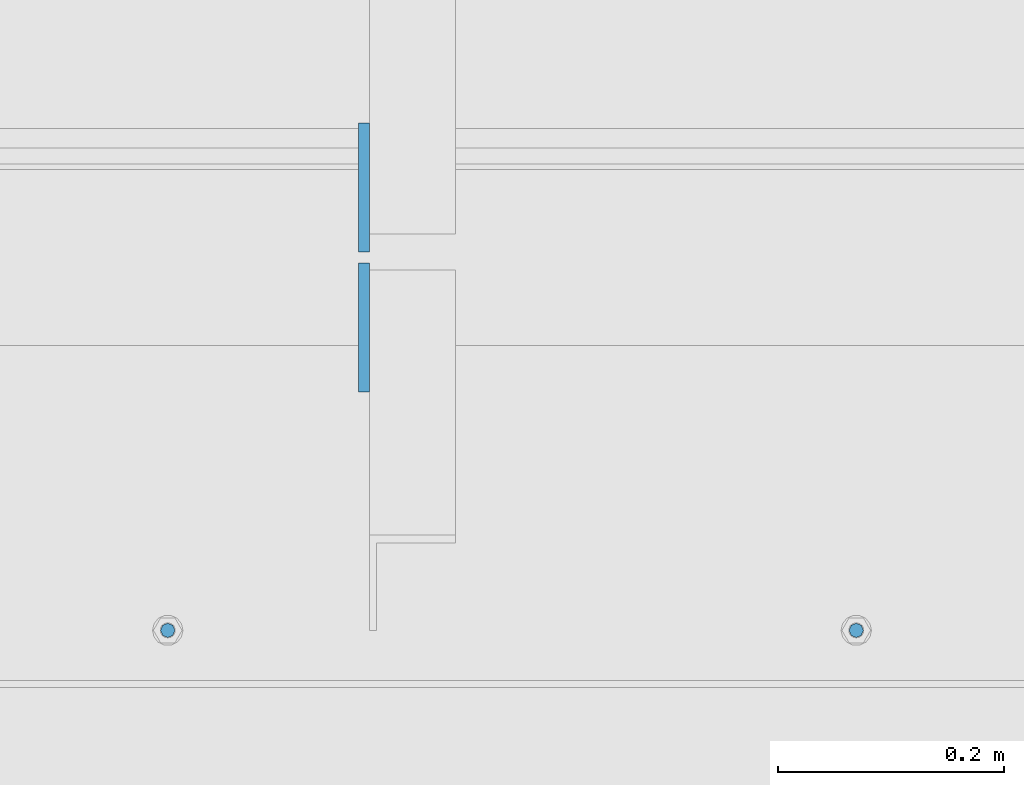
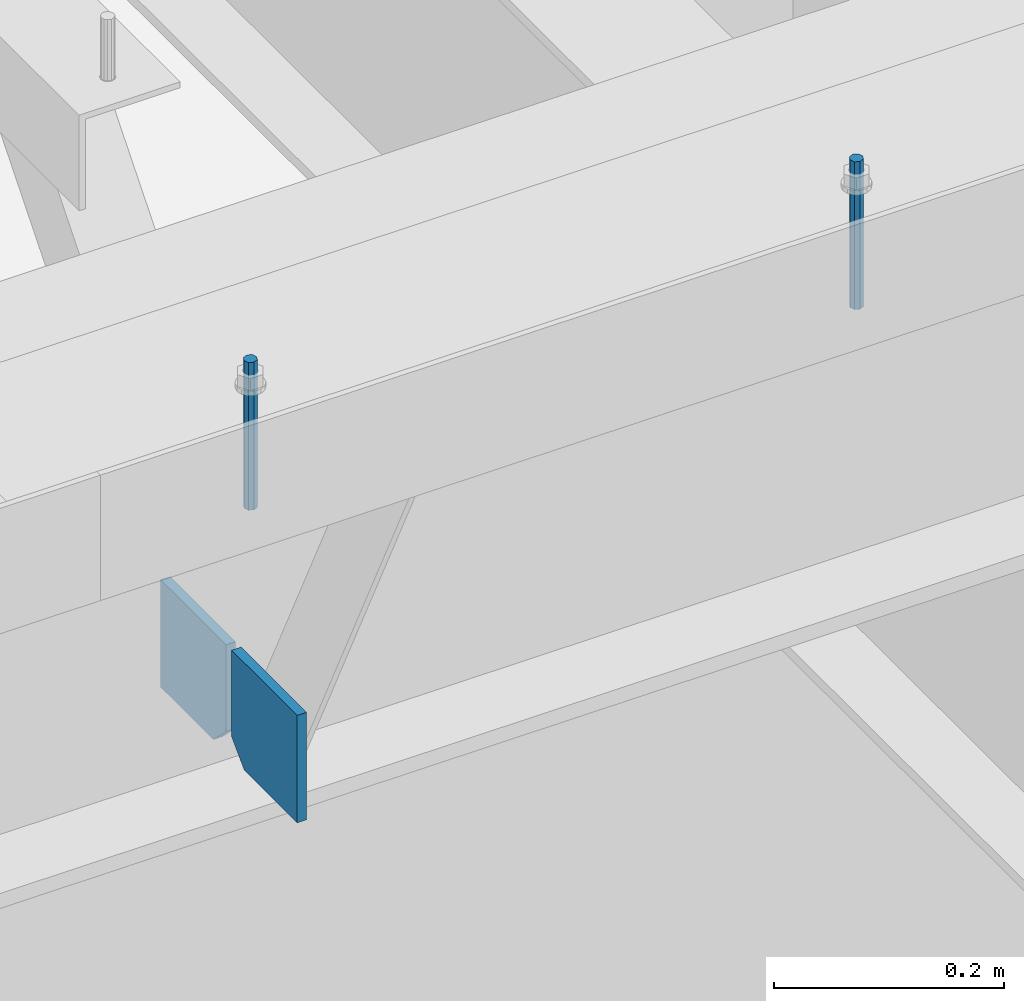
# One storey, part 432 of 1179: 4 columns, 1 element without a shape of its own.
"""IFC2X3 building model written with IfcOpenShell, lengths in millimetres."""

from ifc_helpers import new_model, si_unit, frame, origin_with_axes, place, context, subcontext, project, spatial, faceted_brep, material, type_object, element, aggregate, save


model = new_model("IFC2X3")

# Units and contexts
model_context = context("Model", 3, precision=1e-05, world=origin_with_axes())
body_context = subcontext(model_context, "Body", "Model", "MODEL_VIEW")
ifc_project = project(units=[si_unit("LENGTHUNIT", "METRE", prefix="MILLI"), si_unit("AREAUNIT", "SQUARE_METRE"), si_unit("VOLUMEUNIT", "CUBIC_METRE"), si_unit("MASSUNIT", "GRAM", prefix="KILO"), si_unit("TIMEUNIT", "SECOND"), si_unit("PLANEANGLEUNIT", "RADIAN"), si_unit("SOLIDANGLEUNIT", "STERADIAN"), si_unit("THERMODYNAMICTEMPERATUREUNIT", "DEGREE_CELSIUS"), si_unit("LUMINOUSINTENSITYUNIT", "LUMEN")], contexts=[model_context])

# Site, building, storey
site_placement = place(None, origin_with_axes())
site = spatial("IfcSite", under=ifc_project, at=site_placement, CompositionType="ELEMENT")
building_placement = place(site_placement, origin_with_axes())
building = spatial("IfcBuilding", under=site, at=building_placement, Name="Undefined", CompositionType="ELEMENT")
storey_placement = place(building_placement, origin_with_axes())
storey = spatial("IfcBuildingStorey", under=building, at=storey_placement, Name="Undefined", CompositionType="ELEMENT", Elevation=0.0)

# Assembly, columns
assembly_placement = place(storey_placement, origin_with_axes())
assembly = element("IfcElementAssembly", 1, at=assembly_placement, inside=storey, Name="BEAM", AssemblyPlace="NOTDEFINED", PredefinedType="RIGID_FRAME")
ifc_material_1 = material(Name="STEEL/A36")
column_type_1 = type_object("IfcColumnType", PredefinedType="NOTDEFINED")
column_1_placement = place(assembly_placement, frame((7051.675, 27112.9125, 7496.175), z_axis=(0.0, -1.0, 0.0), x_axis=(0.0, 0.0, 1.0)))
column_1 = element("IfcColumn", 2, at=column_1_placement, type_object=column_type_1, material=ifc_material_1, Name="PLATE", context=body_context, shape_type="Brep", body=[
    faceted_brep([(22.2250000000004, 4.76250000000073, 57.1500000000015), (0.0, 4.76250000000073, 34.9249999999993), (0.0, -4.76250000000073, 34.9249999999993), (22.2250000000004, -4.76250000000073, 57.1500000000015), (114.300000000001, 4.76250000000073, 57.1500000000015), (114.300000000001, 4.76250000000073, -57.1500000000015), (0.0, 4.76250000000073, -57.1500000000015), (114.300000000001, -4.76250000000073, 57.1500000000015), (0.0, -4.76250000000073, -57.1500000000015), (114.300000000001, -4.76250000000073, -57.1500000000015)], [[[0, 1, 2, 3]], [[4, 5, 6, 1, 0]], [[7, 4, 0, 3]], [[8, 9, 7, 3, 2]], [[8, 6, 5, 9]], [[7, 9, 5, 4]], [[6, 8, 2, 1]]]),
])
column_2_placement = place(assembly_placement, frame((7051.675, 26989.0875, 7496.175), z_axis=(0.0, 1.0, 0.0), x_axis=(0.0, 0.0, 1.0)))
column_2 = element("IfcColumn", 3, at=column_2_placement, type_object=column_type_1, material=ifc_material_1, Name="PLATE", context=body_context, shape_type="Brep", body=[
    faceted_brep([(22.2250000000004, 4.76250000000073, 57.1500000000015), (0.0, 4.76250000000073, 34.9249999999993), (0.0, -4.76250000000073, 34.9249999999993), (22.2250000000004, -4.76250000000073, 57.1500000000015), (114.300000000001, 4.76250000000073, 57.1500000000015), (114.300000000001, 4.76250000000073, -57.1500000000015), (0.0, 4.76250000000073, -57.1500000000015), (114.300000000001, -4.76250000000073, 57.1500000000015), (0.0, -4.76250000000073, -57.1500000000015), (114.300000000001, -4.76250000000073, -57.1500000000015)], [[[0, 1, 2, 3]], [[4, 5, 6, 1, 0]], [[7, 4, 0, 3]], [[8, 9, 7, 3, 2]], [[8, 6, 5, 9]], [[7, 9, 5, 4]], [[6, 8, 2, 1]]]),
])
ifc_material_2 = material(Name="STEEL/A307")
column_type_2 = type_object("IfcColumnType", PredefinedType="NOTDEFINED")
column_3_placement = place(assembly_placement, frame((7487.44396123733, 26720.8, 8020.05), z_axis=(0.0, 1.0, 0.0), x_axis=(0.0, 0.0, 1.0)))
column_3 = element("IfcColumn", 4, at=column_3_placement, type_object=column_type_2, material=ifc_material_2, Name="THREADED ROD", context=body_context, shape_type="Brep", body=[
    faceted_brep([(0.0, -6.34999999999854, 0.0), (0.0, -4.49012806053361, -4.49012806053452), (157.162499999999, -4.49012806053361, -4.49012806053361), (157.162499999999, -6.34999999999854, 0.0), (0.0, 0.0, -6.34999999999991), (157.162499999999, 0.0, -6.34999999999854), (0.0, 4.49012806053361, -4.49012806053452), (157.162499999999, 4.49012806053361, -4.49012806053361), (0.0, 6.34999999999854, 0.0), (157.162499999999, 6.34999999999854, 0.0), (0.0, 4.49012806053361, 4.49012806053452), (157.162499999999, 4.49012806053361, 4.49012806053361), (0.0, 0.0, 6.34999999999991), (157.162499999999, 0.0, 6.34999999999854), (0.0, -4.49012806053361, 4.49012806053452), (157.162499999999, -4.49012806053361, 4.49012806053361)], [[[0, 1, 2, 3]], [[1, 4, 5, 2]], [[4, 6, 7, 5]], [[6, 8, 9, 7]], [[8, 10, 11, 9]], [[10, 12, 13, 11]], [[12, 14, 15, 13]], [[14, 0, 3, 15]], [[5, 7, 9, 11, 13, 15, 3, 2]], [[14, 12, 10, 8, 6, 4, 1, 0]]]),
])
column_4_placement = place(assembly_placement, frame((6877.84396123732, 26720.8, 8020.05), z_axis=(0.0, 1.0, 0.0), x_axis=(0.0, 0.0, 1.0)))
column_4 = element("IfcColumn", 5, at=column_4_placement, type_object=column_type_2, material=ifc_material_2, Name="THREADED ROD", context=body_context, shape_type="Brep", body=[
    faceted_brep([(0.0, -6.34999999999854, 0.0), (0.0, -4.49012806053361, -4.49012806053452), (157.162499999999, -4.49012806053361, -4.49012806053361), (157.162499999999, -6.34999999999854, 0.0), (0.0, 0.0, -6.34999999999991), (157.162499999999, 0.0, -6.34999999999854), (0.0, 4.49012806053361, -4.49012806053452), (157.162499999999, 4.49012806053361, -4.49012806053361), (0.0, 6.34999999999854, 0.0), (157.162499999999, 6.34999999999854, 0.0), (0.0, 4.49012806053361, 4.49012806053452), (157.162499999999, 4.49012806053361, 4.49012806053361), (0.0, 0.0, 6.34999999999991), (157.162499999999, 0.0, 6.34999999999854), (0.0, -4.49012806053361, 4.49012806053452), (157.162499999999, -4.49012806053361, 4.49012806053361)], [[[0, 1, 2, 3]], [[1, 4, 5, 2]], [[4, 6, 7, 5]], [[6, 8, 9, 7]], [[8, 10, 11, 9]], [[10, 12, 13, 11]], [[12, 14, 15, 13]], [[14, 0, 3, 15]], [[5, 7, 9, 11, 13, 15, 3, 2]], [[14, 12, 10, 8, 6, 4, 1, 0]]]),
])
aggregate(assembly, [column_3, column_4, column_1, column_2])

save(model, "model.ifc")
